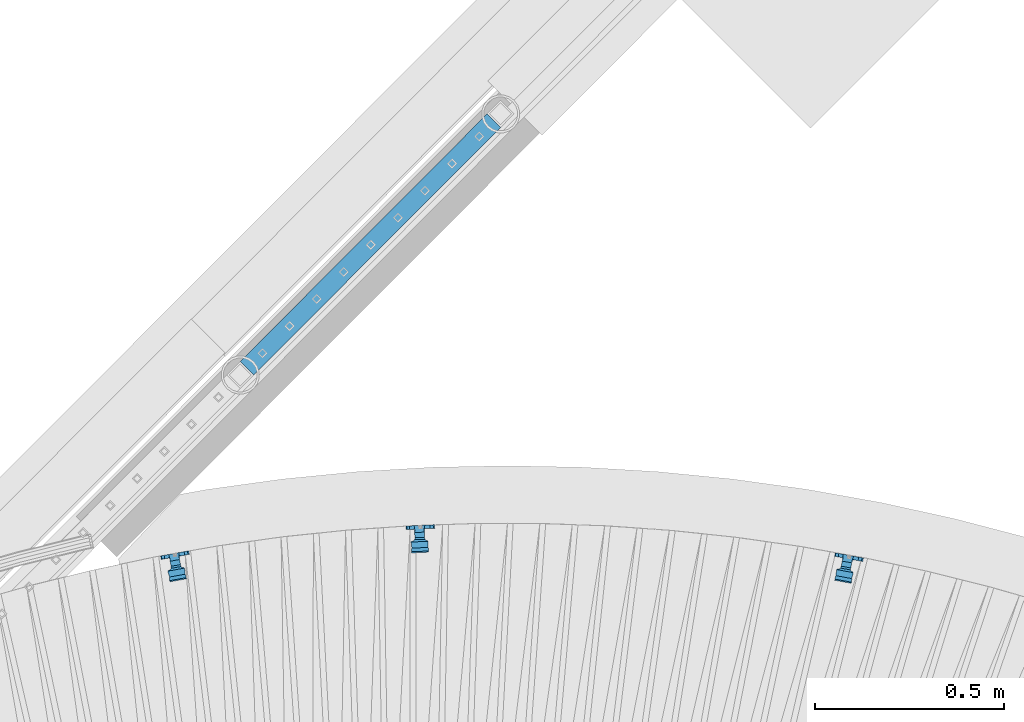
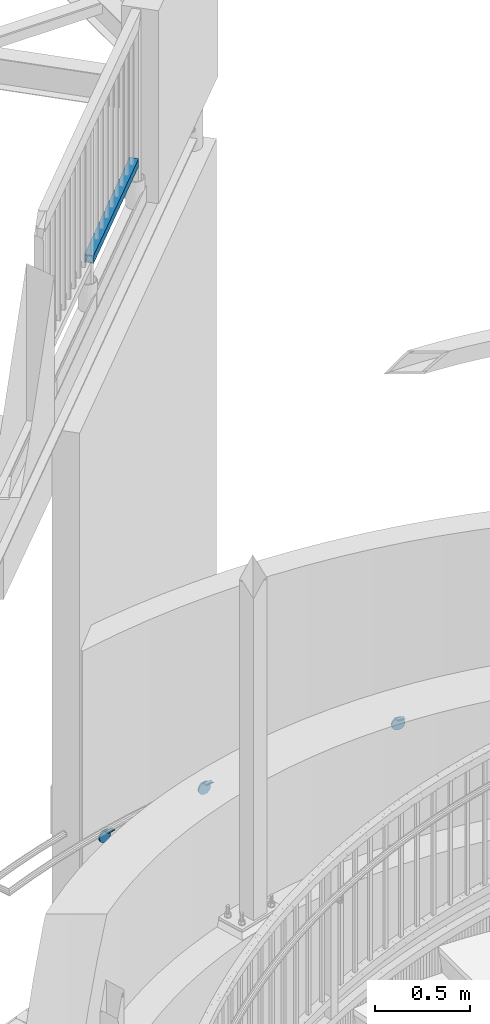
# One storey, part 519 of 975: 4 beams.
"""IFC2X3 building model written with IfcOpenShell, lengths in millimetres."""

from ifc_helpers import new_model, si_unit, frame, origin_with_axes, place, context, subcontext, project, spatial, faceted_brep, material, type_object, element, save


model = new_model("IFC2X3")

# Units and contexts
model_context = context("Model", 3, precision=1e-05, world=origin_with_axes())
body_context = subcontext(model_context, "Body", "Model", "MODEL_VIEW")
ifc_project = project(units=[si_unit("LENGTHUNIT", "METRE", prefix="MILLI"), si_unit("AREAUNIT", "SQUARE_METRE"), si_unit("VOLUMEUNIT", "CUBIC_METRE"), si_unit("MASSUNIT", "GRAM", prefix="KILO"), si_unit("TIMEUNIT", "SECOND"), si_unit("PLANEANGLEUNIT", "RADIAN"), si_unit("SOLIDANGLEUNIT", "STERADIAN"), si_unit("THERMODYNAMICTEMPERATUREUNIT", "DEGREE_CELSIUS"), si_unit("LUMINOUSINTENSITYUNIT", "LUMEN")], contexts=[model_context])

# Site, building, storey
site_placement = place(None, origin_with_axes())
site = spatial("IfcSite", under=ifc_project, at=site_placement, CompositionType="ELEMENT")
building_placement = place(site_placement, origin_with_axes())
building = spatial("IfcBuilding", under=site, at=building_placement, Name="Undefined", CompositionType="ELEMENT")
storey_placement = place(building_placement, origin_with_axes())
storey = spatial("IfcBuildingStorey", under=building, at=storey_placement, Name="Undefined", CompositionType="ELEMENT", Elevation=0.0)

# Beams
ifc_material_1 = material()
beam_type_1 = type_object("IfcBeamType", Name="HSS2X2X.188_TUBES", PredefinedType="NOTDEFINED")
beam_1_placement = place(storey_placement, frame((34025.8598345077, 8724.43901994883, 4229.0999927393), z_axis=(-0.708215788649918, 0.705996031651011, 0.0), x_axis=(0.705996031651012, 0.708215788649917, 7.99999970279175e-09)))
element("IfcBeam", 1, at=beam_1_placement, inside=storey, type_object=beam_type_1, material=ifc_material_1, Name="HANDRAIL", ObjectType="HSS2X2X.188_TUBES", context=body_context, shape_type="Brep", body=[
    faceted_brep([(25.3933485502785, 20.6375000000016, -20.6374999999825), (25.3933834949603, -20.637499999998, -20.6375000000517), (952.494162452385, -20.6374999999198, -20.6375000019216), (952.494162122148, 20.6375000000808, -20.6375000018561), (25.406188500303, -20.637499999998, 20.6374999998698), (952.506967457735, -20.6374999999198, 20.6374999979962), (25.4061535556284, 20.6375000000025, 20.6374999999316), (952.506967127498, 20.6375000000799, 20.6374999980617), (25.3918670175881, 25.4000000000024, -25.3999999999687), (25.4076270241676, 25.4000000000024, 25.3999999999323), (952.50844459001, 25.4000000000797, 25.3999999980624), (952.492684583431, 25.4000000000806, -25.4000000018386), (25.4076700330079, -25.3999999999978, 25.3999999998487), (952.508444996456, -25.3999999999205, 25.3999999979751), (25.3919100264211, -25.3999999999987, -25.4000000000487), (952.492684989877, -25.3999999999196, -25.4000000019223)], [[[0, 1, 2, 3]], [[1, 4, 5, 2]], [[4, 6, 7, 5]], [[6, 0, 3, 7]], [[8, 9, 10, 11]], [[9, 12, 13, 10]], [[12, 14, 15, 13]], [[14, 8, 11, 15]], [[13, 15, 11, 10], [5, 7, 3, 2]], [[14, 12, 9, 8], [6, 4, 1, 0]]]),
])
ifc_material_2 = material(Name="STEEL/A36")
beam_type_2 = type_object("IfcBeamType", PredefinedType="NOTDEFINED")
beam_2_placement = place(storey_placement, frame((35639.5254420315, 8236.61549923592, 978.117810006393), z_axis=(-0.981413631972128, 0.182845482374167, -0.0582650199917106), x_axis=(0.183156638019013, 0.983083743101051, -2.0000051075818e-09)))
element("IfcBeam", 2, at=beam_2_placement, inside=storey, type_object=beam_type_2, material=ifc_material_2, Name="WALL BRACKET", context=body_context, shape_type="Brep", body=[
    faceted_brep([(1.90771711521666, -39.1274654847043, -0.00448519562360161), (4.12781207483931, -37.3142139539234, 11.6585228966114), (9.52543532932032, -37.3142139512213, 11.6585229003122), (9.43572677535121, -39.1274654809358, -0.00448519046040019), (4.12781622100738, -37.3142113462759, -11.6674928794018), (9.52543536164012, -37.3142113435738, -11.6674928757002), (9.52543536943995, -32.9057339591063, -20.5052188302207), (-59.3625452807173, -69.3784655982474, -22.2294880754935), (-59.3625471014821, -69.3784656013463, 22.22051192456), (-62.5372290253217, -65.8290940115519, 22.2205117947715), (-62.5372272045788, -65.829094008453, -22.2294882052784), (-56.0005462189947, -62.6810153936769, -19.4001536583237), (-56.0005462227564, -65.8290917724489, -22.2294876973629), (-56.0005462202826, -62.681015449916, -22.2294879373212), (-51.9926134504567, -65.8290917755876, -22.2294877733802), (-33.6292472686109, -68.3522709460985, 22.2205129786789), (-32.8097419084297, -65.8290964855291, 22.2205130124285), (-39.3123383228012, -65.979826946405, 22.220512746062), (-33.6292454476352, -68.3522709430574, -22.2294870213718), (-39.3123365018328, -65.9798269432699, -22.2294872539878), (-32.8097385636356, -65.8290917906093, -22.2294869876241), (-49.8277636883067, -64.7864958074726, -21.2924544419693), (-49.8277654249105, -64.7864958104751, 21.1008511326818), (-51.9926250505087, -65.8290964884143, 22.2205122266714), (-56.0001150823664, -62.6808069392628, 22.2205120627459), (-56.0005462074841, -65.8290964708895, 22.0378882089371), (-56.0005462048284, -62.681014627902, 19.2085504620054), (-50.6236011268265, -60.0914679008729, -17.0727975240698), (-50.6236025177132, -60.0914679032776, 16.8811960084004), (-37.4815476433287, -61.5838239838195, -18.41405273702), (-37.4843613082412, -61.5826525936984, 18.2213978637983), (-36.5624089686025, -61.9675237354602, -18.7589029365608), (-36.5624104977469, -61.9675237380143, 18.5673007056721), (-35.6656772816132, -59.2065768799944, -16.277501604779), (-35.6656786073509, -59.2065768823657, 16.0859004289514), (-31.1365753532591, -60.6775902087256, -17.5995750168049), (-34.0664704432347, -56.6444110033883, -13.9747547024399), (-28.6192177466946, -56.6444110076541, -13.9747547049501), (-3.23250514597021, -49.4741793712751, -12.2115825119654), (-26.7500778907925, -49.4741793528585, -12.2115825011288), (-23.8991918155225, -47.8232962113207, -12.5029144205391), (-15.4693896953322, -47.5113669671782, -12.5579606869233), (-13.5254114535564, -47.9195514458443, -12.4859282322896), (-10.0154202657941, -47.8634158650693, -12.4958344996949), (-6.87286303067231, -46.2989595909044, -12.7719146400996), (-0.974046807423292, -41.4811318036436, -13.6221183756297), (6.55396309496427, -41.4811318095387, -13.6221183790976), (-3.86056042498967, -49.9871402948386, -12.3377204786066), (-8.88833529744443, -52.4901126906682, -12.9532056622584), (-14.5039675113076, -52.5799239633861, -12.975290406036), (-16.4479457601483, -52.1717394847385, -12.8749171454001), (-22.5788864578426, -52.3986036117494, -12.9307034198746), (-27.8880959805538, -55.4730458560462, -13.6867140147533), (-31.1991459407436, -52.0505332718412, -12.8451123267887), (-8.88833635080664, -52.4901126925429, 12.7616083185248), (-14.503968566496, -52.5799239652715, 12.7836930424628), (-16.4479468071222, -52.171739486608, 12.6833198734348), (-22.5788875093858, -52.3986036136271, 12.7391060973714), (-27.8880970940227, -55.4730458580361, 13.4951160033006), (-31.1365767873285, -60.6775902112895, 17.4079732795044), (-28.6192207215063, -56.6444139540145, 13.783157155035), (-34.0664734189049, -56.6444139511448, 13.7831571531469), (-31.1991469852655, -52.0505332737077, 12.6535150827658), (-26.7500833238446, -49.4741819259821, 12.0199864668184), (-23.8991928320174, -47.823296213136, 12.3113191992961), (-15.469390716331, -47.5113669690018, 12.3663655323317), (-13.5254124686471, -47.9195514476544, 12.294332988411), (-10.0154212816924, -47.8634158668774, 12.3042392674952), (-6.87286406916974, -46.298959592747, 12.5803197484183), (9.52543537061138, -32.9057339862675, -21.3473800764114), (1.90771935590601, -39.1274641541165, -14.9665223671827), (-0.97405142064963, -41.481134668353, 13.4305240281101), (1.90771428571315, -39.1274673022992, 14.7749285169002), (9.52543531150877, -32.9057326102761, 21.316236062763), (9.52543531263655, -32.9057326367222, 20.496260397289), (9.43572925830813, -39.1274641600116, -14.9665223706525), (6.55395824985317, -41.4811346723191, 13.4305240307158), (-3.23250873251527, -49.4741819383717, 12.0199864749611), (-3.86056142790767, -49.9871402966196, 12.1461236957257), (9.43572374406358, -39.1274673062653, 14.7749285195068), (0.0, -26.940768363208, 26.9407683632162), (-1.09139364212751e-11, -35.1998101886752, 14.5802387730655), (9.52499999988504, -35.1998101886779, 14.5802387731401), (9.52499999999418, -26.9407683632098, 26.940768363238), (1.2732925824821e-11, -14.5802387731151, 35.1998101887366), (9.52500000000691, -14.5802387731169, 35.1998101887584), (0.0, 0.0, 38.0999984741211), (9.52500000001783, -1.13686837721616e-11, 38.1000000001295), (3.27418092638254e-11, 14.5802387730973, 35.1998101888166), (9.5250000000251, 14.580238773096, 35.1998101888312), (3.45607986673713e-11, 26.9407683631939, 26.9407683633472), (9.52500000002692, 26.9407683631925, 26.9407683633617), (3.27418092638254e-11, 35.1998101886679, 14.5802387732328), (9.5250000000251, 35.1998101886661, 14.580238773262), (2.36468622460961e-11, 38.0999999999908, 8.73114913702011e-11), (9.52500000001783, 38.099999999989, 1.23691279441118e-10), (1.45519152283669e-11, 35.1998101886752, -14.5802387730655), (9.52500000000509, 35.1998101886734, -14.5802387730364), (1.81898940354586e-12, 26.9407683632071, -26.9407683632162), (9.52499999999418, 26.9407683632057, -26.9407683631944), (-1.09139364212751e-11, 14.5802387731146, -35.1998101887511), (9.52499999997963, 14.5802387731133, -35.199810188722), (0.0, 0.0, -38.0999984741211), (9.52499999996871, 7.73070496506989e-12, -38.1000000000931), (-2.91038304567337e-11, -14.5802387730978, -35.1998101888239), (9.52499999996326, -14.5802387730996, -35.1998101888021), (-3.27418092638254e-11, -26.9407683631948, -26.9407683633617), (9.52499999995962, -26.9407683631966, -26.9407683633399), (-3.09228198602796e-11, -35.1998101886688, -14.5802387732401), (9.5249999999578, -35.1998101886768, -14.5802387731064), (-2.36468622460961e-11, -38.0999999999917, -9.45874489843845e-11), (9.52499999997235, -38.0999999999935, -7.27595761418343e-11)], [[[0, 1, 2, 3]], [[4, 0, 3, 5]], [[4, 5, 6]], [[7, 8, 9, 10]], [[11, 12, 13]], [[7, 10, 13, 12, 14]], [[15, 16, 17]], [[18, 19, 20]], [[17, 19, 18, 15]], [[21, 19, 17, 22]], [[8, 7, 14, 21, 22, 23]], [[24, 9, 8, 23, 25]], [[24, 25, 26]], [[27, 11, 13, 10, 9, 24, 26, 28]], [[29, 27, 28, 30]], [[31, 29, 30, 32]], [[33, 31, 32, 34]], [[35, 20, 19, 21, 14, 12, 11, 27, 29, 31, 33, 36, 37]], [[38, 39, 40, 41, 42, 43, 44, 45, 46]], [[47, 48, 49, 50, 51, 52, 37, 36, 53, 39, 38]], [[49, 48, 54, 55]], [[50, 49, 55, 56]], [[51, 50, 56, 57]], [[52, 51, 57, 58]], [[59, 35, 37, 52, 58, 60]], [[15, 18, 20, 35, 59, 16]], [[60, 61, 34, 32, 30, 28, 26, 25, 23, 22, 17, 16, 59]], [[53, 36, 33, 34, 61, 62]], [[40, 39, 53, 62, 63, 64]], [[41, 40, 64, 65]], [[42, 41, 65, 66]], [[43, 42, 66, 67]], [[44, 43, 67, 68]], [[1, 0, 4, 6, 69, 70, 45, 44, 68, 71, 72, 73, 74]], [[70, 69, 75]], [[46, 45, 70, 75]], [[76, 77, 78, 47, 38, 46, 75, 79]], [[48, 47, 78, 54]], [[77, 63, 62, 61, 60, 58, 57, 56, 55, 54, 78]], [[76, 71, 68, 67, 66, 65, 64, 63, 77]], [[79, 72, 71, 76]], [[72, 79, 73]], [[75, 69, 6, 5, 3, 2, 74, 73, 79]], [[1, 74, 2]], [[80, 81, 82, 83]], [[84, 80, 83, 85]], [[86, 84, 85, 87]], [[88, 86, 87, 89]], [[90, 88, 89, 91]], [[92, 90, 91, 93]], [[94, 92, 93, 95]], [[96, 94, 95, 97]], [[98, 96, 97, 99]], [[100, 98, 99, 101]], [[102, 100, 101, 103]], [[104, 102, 103, 105]], [[106, 104, 105, 107]], [[108, 106, 107, 109]], [[81, 80, 84, 86, 88, 90, 92, 94, 96, 98, 100, 102, 104, 106, 108, 110]], [[81, 110, 111, 82]], [[107, 105, 103, 101, 99, 97, 95, 93, 91, 89, 87, 85, 83, 82, 111, 109]], [[110, 108, 109, 111]]]),
])
beam_3_placement = place(storey_placement, frame((34503.6830749372, 8316.09414229144, 912.130225609307), z_axis=(-0.997200566867829, -0.046863812091511, -0.0582650199925451), x_axis=(-0.0469435620136028, 0.998897543287336, -2.00000510758113e-09)))
element("IfcBeam", 3, at=beam_3_placement, inside=storey, type_object=beam_type_2, material=ifc_material_2, Name="WALL BRACKET", context=body_context, shape_type="Brep", body=[
    faceted_brep([(1.90771711521666, -39.1274654847043, -0.00448519562360161), (4.12781207483931, -37.3142139539234, 11.6585228966114), (9.52543532932032, -37.3142139512213, 11.6585229003122), (9.43572677535121, -39.1274654809358, -0.00448519046040019), (4.12781622100738, -37.3142113462759, -11.6674928794018), (9.52543536164012, -37.3142113435738, -11.6674928757002), (9.52543536943995, -32.9057339591063, -20.5052188302207), (-59.3625452807173, -69.3784655982474, -22.2294880754935), (-59.3625471014821, -69.3784656013463, 22.22051192456), (-62.5372290253217, -65.8290940115519, 22.2205117947715), (-62.5372272045788, -65.829094008453, -22.2294882052784), (-56.0005462189947, -62.6810153936769, -19.4001536583237), (-56.0005462227564, -65.8290917724489, -22.2294876973629), (-56.0005462202826, -62.681015449916, -22.2294879373212), (-51.9926134504567, -65.8290917755876, -22.2294877733802), (-33.6292472686109, -68.3522709460985, 22.2205129786789), (-32.8097419084297, -65.8290964855291, 22.2205130124285), (-39.3123383228012, -65.979826946405, 22.220512746062), (-33.6292454476352, -68.3522709430574, -22.2294870213718), (-39.3123365018328, -65.9798269432699, -22.2294872539878), (-32.8097385636356, -65.8290917906093, -22.2294869876241), (-49.8277636883067, -64.7864958074726, -21.2924544419693), (-49.8277654249105, -64.7864958104751, 21.1008511326818), (-51.9926250505087, -65.8290964884143, 22.2205122266714), (-56.0001150823664, -62.6808069392628, 22.2205120627459), (-56.0005462074841, -65.8290964708895, 22.0378882089371), (-56.0005462048284, -62.681014627902, 19.2085504620054), (-50.6236011268265, -60.0914679008729, -17.0727975240698), (-50.6236025177132, -60.0914679032776, 16.8811960084004), (-37.4815476433287, -61.5838239838195, -18.41405273702), (-37.4843613082412, -61.5826525936984, 18.2213978637983), (-36.5624089686025, -61.9675237354602, -18.7589029365608), (-36.5624104977469, -61.9675237380143, 18.5673007056721), (-35.6656772816132, -59.2065768799944, -16.277501604779), (-35.6656786073509, -59.2065768823657, 16.0859004289514), (-31.1365753532591, -60.6775902087256, -17.5995750168049), (-34.0664704432347, -56.6444110033883, -13.9747547024399), (-28.6192177466946, -56.6444110076541, -13.9747547049501), (-3.23250514597021, -49.4741793712751, -12.2115825119654), (-26.7500778907925, -49.4741793528585, -12.2115825011288), (-23.8991918155225, -47.8232962113207, -12.5029144205391), (-15.4693896953322, -47.5113669671782, -12.5579606869233), (-13.5254114535564, -47.9195514458443, -12.4859282322896), (-10.0154202657941, -47.8634158650693, -12.4958344996949), (-6.87286303067231, -46.2989595909044, -12.7719146400996), (-0.974046807423292, -41.4811318036436, -13.6221183756297), (6.55396309496427, -41.4811318095387, -13.6221183790976), (-3.86056042498967, -49.9871402948386, -12.3377204786066), (-8.88833529744443, -52.4901126906682, -12.9532056622584), (-14.5039675113076, -52.5799239633861, -12.975290406036), (-16.4479457601483, -52.1717394847385, -12.8749171454001), (-22.5788864578426, -52.3986036117494, -12.9307034198746), (-27.8880959805538, -55.4730458560462, -13.6867140147533), (-31.1991459407436, -52.0505332718412, -12.8451123267887), (-8.88833635080664, -52.4901126925429, 12.7616083185248), (-14.503968566496, -52.5799239652715, 12.7836930424628), (-16.4479468071222, -52.171739486608, 12.6833198734348), (-22.5788875093858, -52.3986036136271, 12.7391060973714), (-27.8880970940227, -55.4730458580361, 13.4951160033006), (-31.1365767873285, -60.6775902112895, 17.4079732795044), (-28.6192207215063, -56.6444139540145, 13.783157155035), (-34.0664734189049, -56.6444139511448, 13.7831571531469), (-31.1991469852655, -52.0505332737077, 12.6535150827658), (-26.7500833238446, -49.4741819259821, 12.0199864668184), (-23.8991928320174, -47.823296213136, 12.3113191992961), (-15.469390716331, -47.5113669690018, 12.3663655323317), (-13.5254124686471, -47.9195514476544, 12.294332988411), (-10.0154212816924, -47.8634158668774, 12.3042392674952), (-6.87286406916974, -46.298959592747, 12.5803197484183), (9.52543537061138, -32.9057339862675, -21.3473800764114), (1.90771935590601, -39.1274641541165, -14.9665223671827), (-0.97405142064963, -41.481134668353, 13.4305240281101), (1.90771428571315, -39.1274673022992, 14.7749285169002), (9.52543531150877, -32.9057326102761, 21.316236062763), (9.52543531263655, -32.9057326367222, 20.496260397289), (9.43572925830813, -39.1274641600116, -14.9665223706525), (6.55395824985317, -41.4811346723191, 13.4305240307158), (-3.23250873251527, -49.4741819383717, 12.0199864749611), (-3.86056142790767, -49.9871402966196, 12.1461236957257), (9.43572374406358, -39.1274673062653, 14.7749285195068), (0.0, -26.940768363208, 26.9407683632162), (-1.09139364212751e-11, -35.1998101886752, 14.5802387730655), (9.52499999988504, -35.1998101886779, 14.5802387731401), (9.52499999999418, -26.9407683632098, 26.940768363238), (1.2732925824821e-11, -14.5802387731151, 35.1998101887366), (9.52500000000691, -14.5802387731169, 35.1998101887584), (0.0, 0.0, 38.0999984741211), (9.52500000001783, -1.13686837721616e-11, 38.1000000001295), (3.27418092638254e-11, 14.5802387730973, 35.1998101888166), (9.5250000000251, 14.580238773096, 35.1998101888312), (3.45607986673713e-11, 26.9407683631939, 26.9407683633472), (9.52500000002692, 26.9407683631925, 26.9407683633617), (3.27418092638254e-11, 35.1998101886679, 14.5802387732328), (9.5250000000251, 35.1998101886661, 14.580238773262), (2.36468622460961e-11, 38.0999999999908, 8.73114913702011e-11), (9.52500000001783, 38.099999999989, 1.23691279441118e-10), (1.45519152283669e-11, 35.1998101886752, -14.5802387730655), (9.52500000000509, 35.1998101886734, -14.5802387730364), (1.81898940354586e-12, 26.9407683632071, -26.9407683632162), (9.52499999999418, 26.9407683632057, -26.9407683631944), (-1.09139364212751e-11, 14.5802387731146, -35.1998101887511), (9.52499999997963, 14.5802387731133, -35.199810188722), (0.0, 0.0, -38.0999984741211), (9.52499999996871, 7.73070496506989e-12, -38.1000000000931), (-2.91038304567337e-11, -14.5802387730978, -35.1998101888239), (9.52499999996326, -14.5802387730996, -35.1998101888021), (-3.27418092638254e-11, -26.9407683631948, -26.9407683633617), (9.52499999995962, -26.9407683631966, -26.9407683633399), (-3.09228198602796e-11, -35.1998101886688, -14.5802387732401), (9.5249999999578, -35.1998101886768, -14.5802387731064), (-2.36468622460961e-11, -38.0999999999917, -9.45874489843845e-11), (9.52499999997235, -38.0999999999935, -7.27595761418343e-11)], [[[0, 1, 2, 3]], [[4, 0, 3, 5]], [[4, 5, 6]], [[7, 8, 9, 10]], [[11, 12, 13]], [[7, 10, 13, 12, 14]], [[15, 16, 17]], [[18, 19, 20]], [[17, 19, 18, 15]], [[21, 19, 17, 22]], [[8, 7, 14, 21, 22, 23]], [[24, 9, 8, 23, 25]], [[24, 25, 26]], [[27, 11, 13, 10, 9, 24, 26, 28]], [[29, 27, 28, 30]], [[31, 29, 30, 32]], [[33, 31, 32, 34]], [[35, 20, 19, 21, 14, 12, 11, 27, 29, 31, 33, 36, 37]], [[38, 39, 40, 41, 42, 43, 44, 45, 46]], [[47, 48, 49, 50, 51, 52, 37, 36, 53, 39, 38]], [[49, 48, 54, 55]], [[50, 49, 55, 56]], [[51, 50, 56, 57]], [[52, 51, 57, 58]], [[59, 35, 37, 52, 58, 60]], [[15, 18, 20, 35, 59, 16]], [[60, 61, 34, 32, 30, 28, 26, 25, 23, 22, 17, 16, 59]], [[53, 36, 33, 34, 61, 62]], [[40, 39, 53, 62, 63, 64]], [[41, 40, 64, 65]], [[42, 41, 65, 66]], [[43, 42, 66, 67]], [[44, 43, 67, 68]], [[1, 0, 4, 6, 69, 70, 45, 44, 68, 71, 72, 73, 74]], [[70, 69, 75]], [[46, 45, 70, 75]], [[76, 77, 78, 47, 38, 46, 75, 79]], [[48, 47, 78, 54]], [[77, 63, 62, 61, 60, 58, 57, 56, 55, 54, 78]], [[76, 71, 68, 67, 66, 65, 64, 63, 77]], [[79, 72, 71, 76]], [[72, 79, 73]], [[75, 69, 6, 5, 3, 2, 74, 73, 79]], [[1, 74, 2]], [[80, 81, 82, 83]], [[84, 80, 83, 85]], [[86, 84, 85, 87]], [[88, 86, 87, 89]], [[90, 88, 89, 91]], [[92, 90, 91, 93]], [[94, 92, 93, 95]], [[96, 94, 95, 97]], [[98, 96, 97, 99]], [[100, 98, 99, 101]], [[102, 100, 101, 103]], [[104, 102, 103, 105]], [[106, 104, 105, 107]], [[108, 106, 107, 109]], [[81, 80, 84, 86, 88, 90, 92, 94, 96, 98, 100, 102, 104, 106, 108, 110]], [[81, 110, 111, 82]], [[107, 105, 103, 101, 99, 97, 95, 93, 91, 89, 87, 85, 83, 82, 111, 109]], [[110, 108, 109, 111]]]),
])
beam_4_placement = place(storey_placement, frame((33853.5582471407, 8241.94980487502, 875.315863869467), z_axis=(-0.982133536093654, -0.178938270708931, -0.0582650200023324), x_axis=(-0.179242777064658, 0.983804872355362, -2.00000510758147e-09)))
element("IfcBeam", 4, at=beam_4_placement, inside=storey, type_object=beam_type_2, material=ifc_material_2, Name="WALL BRACKET", context=body_context, shape_type="Brep", body=[
    faceted_brep([(1.2732925824821e-11, -14.5802387731151, 35.1998101887366), (0.0, -26.940768363208, 26.9407683632162), (9.52499999999418, -26.9407683632098, 26.940768363238), (9.52500000000691, -14.5802387731169, 35.1998101887584), (0.0, 0.0, 38.0999984741211), (9.52500000001783, -1.13686837721616e-11, 38.1000000001295), (3.27418092638254e-11, 14.5802387730973, 35.1998101888166), (9.5250000000251, 14.580238773096, 35.1998101888312), (3.45607986673713e-11, 26.9407683631939, 26.9407683633472), (9.52500000002692, 26.9407683631925, 26.9407683633617), (3.27418092638254e-11, 35.1998101886679, 14.5802387732328), (9.5250000000251, 35.1998101886661, 14.580238773262), (2.36468622460961e-11, 38.0999999999908, 8.73114913702011e-11), (9.52500000001783, 38.099999999989, 1.23691279441118e-10), (1.45519152283669e-11, 35.1998101886752, -14.5802387730655), (9.52500000000509, 35.1998101886734, -14.5802387730364), (1.81898940354586e-12, 26.9407683632071, -26.9407683632162), (9.52499999999418, 26.9407683632057, -26.9407683631944), (-1.09139364212751e-11, 14.5802387731146, -35.1998101887511), (9.52499999997963, 14.5802387731133, -35.199810188722), (0.0, 0.0, -38.0999984741211), (9.52499999996871, 7.73070496506989e-12, -38.1000000000931), (-2.91038304567337e-11, -14.5802387730978, -35.1998101888239), (9.52499999996326, -14.5802387730996, -35.1998101888021), (-3.27418092638254e-11, -26.9407683631948, -26.9407683633617), (9.52499999995962, -26.9407683631966, -26.9407683633399), (-1.09139364212751e-11, -35.1998101886752, 14.5802387730655), (-3.09228198602796e-11, -35.1998101886688, -14.5802387732401), (-2.36468622460961e-11, -38.0999999999917, -9.45874489843845e-11), (5.15916151986676, -35.4440470179043, 13.3523773160632), (5.45819836063492, -35.1998101886761, 14.5802387730728), (9.52499999997235, -38.0999999999935, -7.27595761418343e-11), (9.52500000450709, -35.4440470179088, 13.3523773160487), (7.2371100059845, -33.7468932558072, 16.754682627492), (9.52500000451801, -33.7468932557954, 16.7546826275138), (9.52500000445798, -35.4440462189814, -13.3523813326392), (9.52500000445798, -33.7468952491577, -16.7546796443567), (7.23710890894472, -33.7468952491804, -16.7546796443348), (5.4581995298613, -35.1998101886693, -14.5802387732328), (5.15916356880916, -35.4440462189727, -13.3523813326829), (9.52500000445434, -31.8782721836319, -20.5007300630459), (-59.362980674241, -68.3509998739587, -22.2250071919989), (-59.3629824602704, -68.3509998769764, 22.2249928081292), (-62.5376644231455, -64.8016283221027, 22.2249926808072), (-62.537662637118, -64.8016283190846, -22.2250073193209), (-56.0009815912945, -61.6535496682918, -19.3956727407494), (-56.000981591309, -64.8016260898362, -22.2250068172871), (-56.0009815912999, -61.6535497228529, -22.225007056426), (-51.9930489428643, -64.8016260898294, -22.2250068955836), (-33.6296835776757, -67.3248053616639, 22.2249938423338), (-32.8101777262855, -64.8016307488883, 22.2249938754467), (-39.3127739489937, -64.9523614530367, 22.2249936141088), (-33.6296817914808, -67.3248053586817, -22.2250061577943), (-39.3127721627934, -64.9523614499894, -22.225006386012), (-32.8101744278647, -64.8016260897953, -22.2250061246668), (-49.8281991999065, -63.7590301286368, -21.2879735671377), (-49.8282009033755, -63.7590301315527, 21.1053320839419), (-51.9930604234723, -64.8016307617759, 22.2249931045444), (-56.0005504677993, -61.6533412357799, 22.2249929437239), (-56.0009815912108, -64.8016307465336, 22.0423691210235), (-56.000981591209, -61.6535489237508, 19.2130313848393), (-50.6240365928552, -59.0640022148641, -17.068316644014), (-50.62403795721, -59.0640022171988, 16.8856769420818), (-37.4819831736677, -60.5563585436898, -18.4095720806508), (-37.4847968100603, -60.5551871533557, 18.2258790235646), (-36.5628445055427, -60.9400583240672, -18.7544223061341), (-36.5628460054704, -60.940058326571, 18.5717818924459), (-35.666111145687, -58.1791078124638, -16.2730176894474), (-35.6661124461261, -58.1791078147403, 16.0903783233516), (-31.1370094513986, -59.6501218585477, -17.5950917468435), (-34.0669059000666, -55.6169453021639, -13.9702738136984), (-28.6196526953099, -55.6169453021544, -13.9702738136766), (-3.23293649958759, -48.4467136455532, -12.207101610089), (-26.7505137989156, -48.4467136455951, -12.207101610169), (-23.8996249546344, -46.7958293195065, -12.4984337370406), (-15.4698233557392, -46.4839007520641, -12.5534798790104), (-13.5258434309762, -46.892085709494, -12.4814473386505), (-10.0158521010289, -46.8359503118018, -12.4913535716478), (-6.87329468697135, -45.2714940850042, -12.7674337020799), (-0.974477882295105, -40.4536660763902, -13.6176374740317), (6.55353226544685, -40.4536660763761, -13.6176374740171), (-3.86099217626361, -48.9596748667777, -12.3332396499609), (-8.88876733573125, -51.4626471867787, -12.9487248158839), (-14.5043997770172, -51.5524581665836, -12.9708094891394), (-16.4483797087032, -51.1442732091714, -12.8704361113705), (-22.5793200272747, -51.3711368440199, -12.9262222664329), (-27.8885295453638, -54.4455783048938, -13.6822326695547), (-31.199579073018, -51.0230653028852, -12.840630880346), (-8.88876836899726, -51.4626471885831, 12.7660892544445), (-14.504400812064, -51.5524581683962, 12.7881739076765), (-16.4483807356864, -51.1442732109658, 12.6878006207626), (-22.5793210587417, -51.3711368458225, 12.7435867252934), (-27.8885306375905, -54.4455783068047, 13.4995964439586), (-31.1370108580904, -59.6501218610088, 17.4124518226672), (-28.6196556343875, -55.6169482259406, 13.7876380457747), (-34.0669088391423, -55.6169482259506, 13.7876380457601), (-31.1995800976092, -51.0230653046779, 12.6579954166664), (-26.7505191794698, -48.4467161992197, 12.0244673476045), (-23.8996259517189, -46.7958293212487, 12.3158002822529), (-15.4698243572475, -46.4839007538158, 12.3708464917727), (-13.5258444266965, -46.8920857112348, 12.2988138630608), (-10.0158530975405, -46.8359503135416, 12.3087201082308), (-6.87329570566908, -45.2714940867804, 12.5848005773296), (4.1273854062656, -36.2867456275421, -11.663012015495), (9.5250000044598, -36.286745627533, -11.6630120154732), (1.90728621943163, -38.0999997439571, -4.32692468166351e-06), (9.43529700414729, -38.0999997439435, -4.32690285379067e-06), (4.12738132945015, -36.2867481933758, 11.6630037605864), (9.52500000449982, -36.2867481933667, 11.663003760601), (9.52500000452892, -31.8782708408467, 20.5007332856403), (9.52500000445252, -31.8782722112123, -21.3428951777532), (1.9072884344514, -38.0999984248297, -14.9620414646415), (-0.974482456142141, -40.4536689261299, 13.4350048896813), (1.90728340723763, -38.1000015568025, 14.7794093744233), (9.52500000452892, -31.8782708139925, 21.3207127303758), (9.43529858219699, -38.099998424816, -14.9620414646197), (6.55352759261223, -40.4536689261167, 13.4350048897031), (-3.23294036661173, -48.4467161991774, 12.0244673476845), (-3.86099316006766, -48.9596748684935, 12.1506046457653), (9.43529336634128, -38.1000015567884, 14.7794093744451)], [[[0, 1, 2, 3]], [[4, 0, 3, 5]], [[6, 4, 5, 7]], [[8, 6, 7, 9]], [[10, 8, 9, 11]], [[12, 10, 11, 13]], [[14, 12, 13, 15]], [[16, 14, 15, 17]], [[18, 16, 17, 19]], [[20, 18, 19, 21]], [[22, 20, 21, 23]], [[24, 22, 23, 25]], [[26, 1, 0, 4, 6, 8, 10, 12, 14, 16, 18, 20, 22, 24, 27, 28]], [[29, 30, 26, 28, 31, 32]], [[33, 34, 2, 1, 26, 30]], [[32, 31, 35, 36, 25, 23, 21, 19, 17, 15, 13, 11, 9, 7, 5, 3, 2, 34]], [[37, 38, 27, 24, 25, 36]], [[39, 35, 31, 28, 27, 38]], [[40, 37, 36]], [[41, 42, 43, 44]], [[45, 46, 47]], [[41, 44, 47, 46, 48]], [[49, 50, 51]], [[52, 53, 54]], [[51, 53, 52, 49]], [[55, 53, 51, 56]], [[42, 41, 48, 55, 56, 57]], [[58, 43, 42, 57, 59]], [[58, 59, 60]], [[61, 45, 47, 44, 43, 58, 60, 62]], [[63, 61, 62, 64]], [[65, 63, 64, 66]], [[67, 65, 66, 68]], [[69, 54, 53, 55, 48, 46, 45, 61, 63, 65, 67, 70, 71]], [[72, 73, 74, 75, 76, 77, 78, 79, 80]], [[81, 82, 83, 84, 85, 86, 71, 70, 87, 73, 72]], [[83, 82, 88, 89]], [[84, 83, 89, 90]], [[85, 84, 90, 91]], [[86, 85, 91, 92]], [[93, 69, 71, 86, 92, 94]], [[49, 52, 54, 69, 93, 50]], [[94, 95, 68, 66, 64, 62, 60, 59, 57, 56, 51, 50, 93]], [[87, 70, 67, 68, 95, 96]], [[74, 73, 87, 96, 97, 98]], [[75, 74, 98, 99]], [[76, 75, 99, 100]], [[77, 76, 100, 101]], [[78, 77, 101, 102]], [[103, 104, 35, 39]], [[103, 105, 106, 104]], [[105, 107, 108, 106]], [[108, 107, 29, 32]], [[109, 34, 33]], [[29, 107, 105, 103, 39, 38, 37, 40, 110, 111, 79, 78, 102, 112, 113, 114, 109, 33, 30]], [[111, 110, 115]], [[80, 79, 111, 115]], [[116, 117, 118, 81, 72, 80, 115, 119]], [[82, 81, 118, 88]], [[117, 97, 96, 95, 94, 92, 91, 90, 89, 88, 118]], [[116, 112, 102, 101, 100, 99, 98, 97, 117]], [[119, 113, 112, 116]], [[113, 119, 114]], [[115, 110, 40, 36, 35, 104, 106, 108, 32, 34, 109, 114, 119]]]),
])

save(model, "model.ifc")
